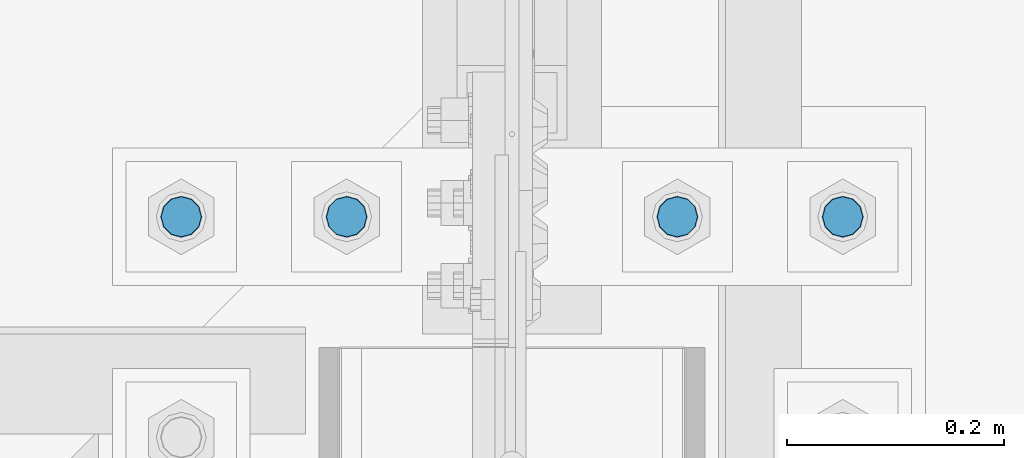
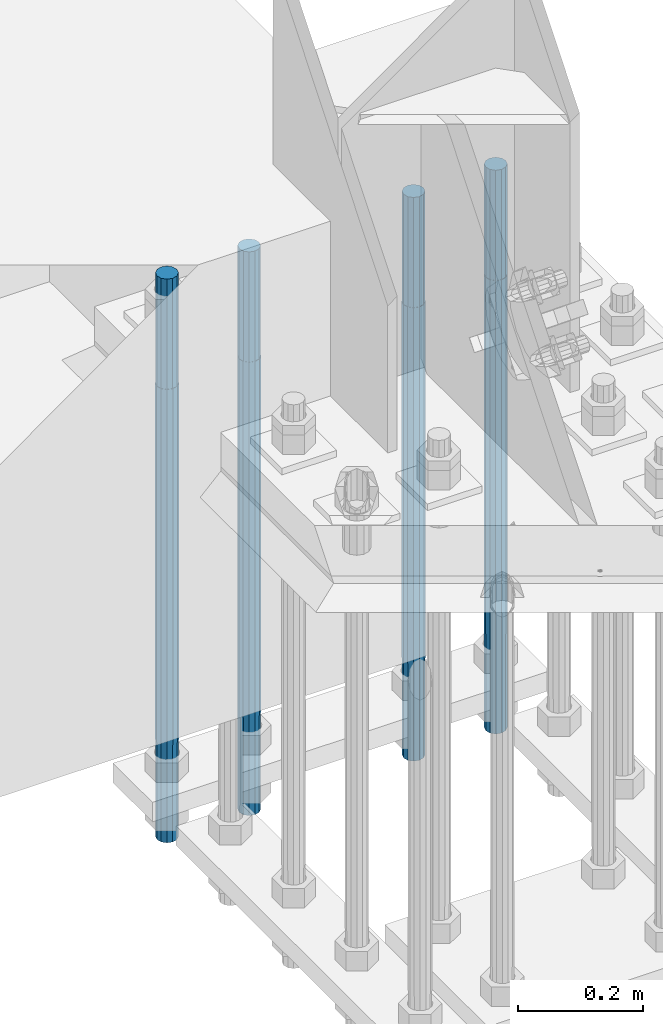
# One storey, part 1318 of 3843: 4 columns, 1 element without a shape of its own.
"""IFC2X3 building model written with IfcOpenShell, lengths in millimetres."""

from ifc_helpers import new_model, si_unit, frame, origin_with_axes, place, context, subcontext, project, spatial, faceted_brep, material, type_object, element, aggregate, save


model = new_model("IFC2X3")

# Units and contexts
model_context = context("Model", 3, precision=1e-05, world=origin_with_axes())
body_context = subcontext(model_context, "Body", "Model", "MODEL_VIEW")
ifc_project = project(units=[si_unit("LENGTHUNIT", "METRE", prefix="MILLI"), si_unit("AREAUNIT", "SQUARE_METRE"), si_unit("VOLUMEUNIT", "CUBIC_METRE"), si_unit("MASSUNIT", "GRAM", prefix="KILO"), si_unit("TIMEUNIT", "SECOND"), si_unit("PLANEANGLEUNIT", "RADIAN"), si_unit("SOLIDANGLEUNIT", "STERADIAN"), si_unit("THERMODYNAMICTEMPERATUREUNIT", "DEGREE_CELSIUS"), si_unit("LUMINOUSINTENSITYUNIT", "LUMEN")], contexts=[model_context])

# Site, building, storey
site_placement = place(None, origin_with_axes())
site = spatial("IfcSite", under=ifc_project, at=site_placement, CompositionType="ELEMENT")
building_placement = place(site_placement, origin_with_axes())
building = spatial("IfcBuilding", under=site, at=building_placement, Name="Undefined", CompositionType="ELEMENT")
storey_placement = place(building_placement, origin_with_axes())
storey = spatial("IfcBuildingStorey", under=building, at=storey_placement, Name="Undefined", CompositionType="ELEMENT", Elevation=0.0)

# Assembly, columns
assembly_placement = place(storey_placement, origin_with_axes())
assembly = element("IfcElementAssembly", 1, at=assembly_placement, inside=storey, Name="TEMPLATE", AssemblyPlace="NOTDEFINED", PredefinedType="RIGID_FRAME")
ifc_material = material(Name="Undefined/F1554-GR.55")
column_type = type_object("IfcColumnType", PredefinedType="NOTDEFINED")
column_1_placement = place(assembly_placement, frame((77317.6, 25920.7, 30022.8), z_axis=(-1.0, 0.0, 0.0), x_axis=(0.0, 0.0, -1.0)))
column_1 = element("IfcColumn", 2, at=column_1_placement, type_object=column_type, material=ifc_material, Name="ANCHOR_ROD", context=body_context, shape_type="Brep", body=[
    faceted_brep([(-215.899999999998, -16.0214699700118, 9.25), (-215.899999999998, -9.25, 16.0214699700155), (-215.899999999998, 0.0, 18.5), (-215.899999999998, 9.25, 16.0214699700155), (-215.899999999998, 16.0214699700118, 9.25), (-215.899999999998, 18.5, 0.0), (-215.899999999998, 16.0214699700118, -9.25), (-215.899999999998, 9.25, -16.0214699700155), (-215.899999999998, 0.0, -18.5), (-215.899999999998, -9.25, -16.0214699700155), (-215.899999999998, -16.0214699700118, -9.25), (-215.899999999998, -18.5, 0.0), (0.0, 18.5, 0.0), (0.0, 16.0214699700118, -9.25), (0.0, 9.25, -16.0214699700155), (0.0, 0.0, -18.5), (0.0, -9.25, -16.0214699700155), (0.0, -16.0214699700118, -9.25), (0.0, -18.5, 0.0), (0.0, -16.0214699700118, 9.25), (0.0, -9.25, 16.0214699700155), (0.0, 0.0, 18.5), (0.0, 9.25, 16.0214699700155), (0.0, 16.0214699700118, 9.25), (0.0, -16.4977839420972, 9.52500000000146), (0.0, -9.52500000000146, 16.4977839420972), (0.0, 0.0, 19.0499989999989), (0.0, 9.52500000000146, 16.4977839420972), (0.0, 16.4977839420972, 9.52500000000146), (0.0, 19.0500000000029, 0.0), (0.0, 16.4977839420972, -9.52500000000146), (0.0, 9.52500000000146, -16.4977839420972), (0.0, 0.0, -19.0499989999989), (0.0, -9.52500000000146, -16.4977839420972), (0.0, -16.4977839420972, -9.52500000000146), (0.0, -19.0500000000029, 0.0), (698.5, -19.0499999999993, 0.0), (698.5, -16.4977839420935, 9.52499999999418), (698.5, -9.52500000000146, 16.4977839420899), (698.5, 0.0, 19.0500000000029), (698.5, 9.52500000000146, 16.4977839420899), (698.5, 16.4977839420935, 9.52499999999418), (698.5, 19.0499999999993, 0.0), (698.5, 16.4977839420935, -9.52499999999418), (698.5, 9.52500000000146, -16.4977839420899), (698.5, 0.0, -19.0500000000029), (698.5, -9.52500000000146, -16.4977839420899), (698.5, -16.4977839420935, -9.52499999999418), (698.5, -9.25, 16.0214699700155), (698.5, 0.0, 18.5), (698.5, 9.25, 16.0214699700155), (698.5, 16.0214699700118, 9.25), (698.5, 18.5, 0.0), (698.5, 16.0214699700118, -9.25), (698.5, 9.25, -16.0214699700155), (698.5, 0.0, -18.5), (698.5, -9.25, -16.0214699700155), (698.5, -16.0214699700118, -9.25), (698.5, -18.5, 0.0), (698.5, -16.0214699700118, 9.25), (889.0, -9.25, -16.0214699700155), (889.0, 0.0, -18.5), (889.0, 9.25, -16.0214699700155), (889.0, 16.0214699700118, -9.25), (889.0, 18.5, 0.0), (889.0, 16.0214699700118, 9.25), (889.0, 9.25, 16.0214699700155), (889.0, 0.0, 18.5), (889.0, -9.25, 16.0214699700155), (889.0, -16.0214699700118, 9.25), (889.0, -18.5, 0.0), (889.0, -16.0214699700118, -9.25)], [[[0, 1, 2, 3, 4, 5, 6, 7, 8, 9, 10, 11]], [[6, 5, 12, 13]], [[7, 6, 13, 14]], [[8, 7, 14, 15]], [[9, 8, 15, 16]], [[10, 9, 16, 17]], [[11, 10, 17, 18]], [[0, 11, 18, 19]], [[1, 0, 19, 20]], [[2, 1, 20, 21]], [[3, 2, 21, 22]], [[4, 3, 22, 23]], [[5, 4, 23, 12]], [[24, 25, 26, 27, 28, 29, 30, 31, 32, 33, 34, 35], [22, 21, 20, 19, 18, 17, 16, 15, 14, 13, 12, 23]], [[24, 35, 36, 37]], [[25, 24, 37, 38]], [[26, 25, 38, 39]], [[27, 26, 39, 40]], [[28, 27, 40, 41]], [[29, 28, 41, 42]], [[30, 29, 42, 43]], [[31, 30, 43, 44]], [[32, 31, 44, 45]], [[33, 32, 45, 46]], [[34, 33, 46, 47]], [[35, 34, 47, 36]], [[46, 45, 44, 43, 42, 41, 40, 39, 38, 37, 36, 47], [48, 49, 50, 51, 52, 53, 54, 55, 56, 57, 58, 59]], [[60, 61, 62, 63, 64, 65, 66, 67, 68, 69, 70, 71]], [[68, 67, 49, 48]], [[69, 68, 48, 59]], [[70, 69, 59, 58]], [[71, 70, 58, 57]], [[60, 71, 57, 56]], [[61, 60, 56, 55]], [[62, 61, 55, 54]], [[63, 62, 54, 53]], [[64, 63, 53, 52]], [[65, 64, 52, 51]], [[66, 65, 51, 50]], [[67, 66, 50, 49]]]),
])
column_2_placement = place(assembly_placement, frame((77165.2, 25920.7, 30022.8), z_axis=(-1.0, 0.0, 0.0), x_axis=(0.0, 0.0, -1.0)))
column_2 = element("IfcColumn", 3, at=column_2_placement, type_object=column_type, material=ifc_material, Name="ANCHOR_ROD", context=body_context, shape_type="Brep", body=[
    faceted_brep([(-215.899999999998, -16.0214699700118, 9.25), (-215.899999999998, -9.25, 16.0214699700155), (-215.899999999998, 0.0, 18.5), (-215.899999999998, 9.25, 16.0214699700155), (-215.899999999998, 16.0214699700118, 9.25), (-215.899999999998, 18.5, 0.0), (-215.899999999998, 16.0214699700118, -9.25), (-215.899999999998, 9.25, -16.0214699700155), (-215.899999999998, 0.0, -18.5), (-215.899999999998, -9.25, -16.0214699700155), (-215.899999999998, -16.0214699700118, -9.25), (-215.899999999998, -18.5, 0.0), (0.0, 18.5, 0.0), (0.0, 16.0214699700118, -9.25), (0.0, 9.25, -16.0214699700155), (0.0, 0.0, -18.5), (0.0, -9.25, -16.0214699700155), (0.0, -16.0214699700118, -9.25), (0.0, -18.5, 0.0), (0.0, -16.0214699700118, 9.25), (0.0, -9.25, 16.0214699700155), (0.0, 0.0, 18.5), (0.0, 9.25, 16.0214699700155), (0.0, 16.0214699700118, 9.25), (0.0, -16.4977839420972, 9.52500000000146), (0.0, -9.52500000000146, 16.4977839420972), (0.0, 0.0, 19.0499989999989), (0.0, 9.52500000000146, 16.4977839420972), (0.0, 16.4977839420972, 9.52500000000146), (0.0, 19.0500000000029, 0.0), (0.0, 16.4977839420972, -9.52500000000146), (0.0, 9.52500000000146, -16.4977839420972), (0.0, 0.0, -19.0499989999989), (0.0, -9.52500000000146, -16.4977839420972), (0.0, -16.4977839420972, -9.52500000000146), (0.0, -19.0500000000029, 0.0), (698.5, -19.0499999999993, 0.0), (698.5, -16.4977839420935, 9.52499999999418), (698.5, -9.52500000000146, 16.4977839420899), (698.5, 0.0, 19.0500000000029), (698.5, 9.52500000000146, 16.4977839420899), (698.5, 16.4977839420935, 9.52499999999418), (698.5, 19.0499999999993, 0.0), (698.5, 16.4977839420935, -9.52499999999418), (698.5, 9.52500000000146, -16.4977839420899), (698.5, 0.0, -19.0500000000029), (698.5, -9.52500000000146, -16.4977839420899), (698.5, -16.4977839420935, -9.52499999999418), (698.5, -9.25, 16.0214699700155), (698.5, 0.0, 18.5), (698.5, 9.25, 16.0214699700155), (698.5, 16.0214699700118, 9.25), (698.5, 18.5, 0.0), (698.5, 16.0214699700118, -9.25), (698.5, 9.25, -16.0214699700155), (698.5, 0.0, -18.5), (698.5, -9.25, -16.0214699700155), (698.5, -16.0214699700118, -9.25), (698.5, -18.5, 0.0), (698.5, -16.0214699700118, 9.25), (889.0, -9.25, -16.0214699700155), (889.0, 0.0, -18.5), (889.0, 9.25, -16.0214699700155), (889.0, 16.0214699700118, -9.25), (889.0, 18.5, 0.0), (889.0, 16.0214699700118, 9.25), (889.0, 9.25, 16.0214699700155), (889.0, 0.0, 18.5), (889.0, -9.25, 16.0214699700155), (889.0, -16.0214699700118, 9.25), (889.0, -18.5, 0.0), (889.0, -16.0214699700118, -9.25)], [[[0, 1, 2, 3, 4, 5, 6, 7, 8, 9, 10, 11]], [[6, 5, 12, 13]], [[7, 6, 13, 14]], [[8, 7, 14, 15]], [[9, 8, 15, 16]], [[10, 9, 16, 17]], [[11, 10, 17, 18]], [[0, 11, 18, 19]], [[1, 0, 19, 20]], [[2, 1, 20, 21]], [[3, 2, 21, 22]], [[4, 3, 22, 23]], [[5, 4, 23, 12]], [[24, 25, 26, 27, 28, 29, 30, 31, 32, 33, 34, 35], [22, 21, 20, 19, 18, 17, 16, 15, 14, 13, 12, 23]], [[24, 35, 36, 37]], [[25, 24, 37, 38]], [[26, 25, 38, 39]], [[27, 26, 39, 40]], [[28, 27, 40, 41]], [[29, 28, 41, 42]], [[30, 29, 42, 43]], [[31, 30, 43, 44]], [[32, 31, 44, 45]], [[33, 32, 45, 46]], [[34, 33, 46, 47]], [[35, 34, 47, 36]], [[46, 45, 44, 43, 42, 41, 40, 39, 38, 37, 36, 47], [48, 49, 50, 51, 52, 53, 54, 55, 56, 57, 58, 59]], [[60, 61, 62, 63, 64, 65, 66, 67, 68, 69, 70, 71]], [[68, 67, 49, 48]], [[69, 68, 48, 59]], [[70, 69, 59, 58]], [[71, 70, 58, 57]], [[60, 71, 57, 56]], [[61, 60, 56, 55]], [[62, 61, 55, 54]], [[63, 62, 54, 53]], [[64, 63, 53, 52]], [[65, 64, 52, 51]], [[66, 65, 51, 50]], [[67, 66, 50, 49]]]),
])
column_3_placement = place(assembly_placement, frame((76860.4, 25920.7, 30022.8), z_axis=(-1.0, 0.0, 0.0), x_axis=(0.0, 0.0, -1.0)))
column_3 = element("IfcColumn", 4, at=column_3_placement, type_object=column_type, material=ifc_material, Name="ANCHOR_ROD", context=body_context, shape_type="Brep", body=[
    faceted_brep([(-215.899999999998, -16.0214699700118, 9.25), (-215.899999999998, -9.25, 16.0214699700155), (-215.899999999998, 0.0, 18.5), (-215.899999999998, 9.25, 16.0214699700155), (-215.899999999998, 16.0214699700118, 9.25), (-215.899999999998, 18.5, 0.0), (-215.899999999998, 16.0214699700118, -9.25), (-215.899999999998, 9.25, -16.0214699700155), (-215.899999999998, 0.0, -18.5), (-215.899999999998, -9.25, -16.0214699700155), (-215.899999999998, -16.0214699700118, -9.25), (-215.899999999998, -18.5, 0.0), (0.0, 18.5, 0.0), (0.0, 16.0214699700118, -9.25), (0.0, 9.25, -16.0214699700155), (0.0, 0.0, -18.5), (0.0, -9.25, -16.0214699700155), (0.0, -16.0214699700118, -9.25), (0.0, -18.5, 0.0), (0.0, -16.0214699700118, 9.25), (0.0, -9.25, 16.0214699700155), (0.0, 0.0, 18.5), (0.0, 9.25, 16.0214699700155), (0.0, 16.0214699700118, 9.25), (0.0, -16.4977839420972, 9.52500000000146), (0.0, -9.52500000000146, 16.4977839420972), (0.0, 0.0, 19.0499989999989), (0.0, 9.52500000000146, 16.4977839420972), (0.0, 16.4977839420972, 9.52500000000146), (0.0, 19.0500000000029, 0.0), (0.0, 16.4977839420972, -9.52500000000146), (0.0, 9.52500000000146, -16.4977839420972), (0.0, 0.0, -19.0499989999989), (0.0, -9.52500000000146, -16.4977839420972), (0.0, -16.4977839420972, -9.52500000000146), (0.0, -19.0500000000029, 0.0), (698.5, -19.0499999999993, 0.0), (698.5, -16.4977839420935, 9.52499999999418), (698.5, -9.52500000000146, 16.4977839420899), (698.5, 0.0, 19.0500000000029), (698.5, 9.52500000000146, 16.4977839420899), (698.5, 16.4977839420935, 9.52499999999418), (698.5, 19.0499999999993, 0.0), (698.5, 16.4977839420935, -9.52499999999418), (698.5, 9.52500000000146, -16.4977839420899), (698.5, 0.0, -19.0500000000029), (698.5, -9.52500000000146, -16.4977839420899), (698.5, -16.4977839420935, -9.52499999999418), (698.5, -9.25, 16.0214699700155), (698.5, 0.0, 18.5), (698.5, 9.25, 16.0214699700155), (698.5, 16.0214699700118, 9.25), (698.5, 18.5, 0.0), (698.5, 16.0214699700118, -9.25), (698.5, 9.25, -16.0214699700155), (698.5, 0.0, -18.5), (698.5, -9.25, -16.0214699700155), (698.5, -16.0214699700118, -9.25), (698.5, -18.5, 0.0), (698.5, -16.0214699700118, 9.25), (889.0, -9.25, -16.0214699700155), (889.0, 0.0, -18.5), (889.0, 9.25, -16.0214699700155), (889.0, 16.0214699700118, -9.25), (889.0, 18.5, 0.0), (889.0, 16.0214699700118, 9.25), (889.0, 9.25, 16.0214699700155), (889.0, 0.0, 18.5), (889.0, -9.25, 16.0214699700155), (889.0, -16.0214699700118, 9.25), (889.0, -18.5, 0.0), (889.0, -16.0214699700118, -9.25)], [[[0, 1, 2, 3, 4, 5, 6, 7, 8, 9, 10, 11]], [[6, 5, 12, 13]], [[7, 6, 13, 14]], [[8, 7, 14, 15]], [[9, 8, 15, 16]], [[10, 9, 16, 17]], [[11, 10, 17, 18]], [[0, 11, 18, 19]], [[1, 0, 19, 20]], [[2, 1, 20, 21]], [[3, 2, 21, 22]], [[4, 3, 22, 23]], [[5, 4, 23, 12]], [[24, 25, 26, 27, 28, 29, 30, 31, 32, 33, 34, 35], [22, 21, 20, 19, 18, 17, 16, 15, 14, 13, 12, 23]], [[24, 35, 36, 37]], [[25, 24, 37, 38]], [[26, 25, 38, 39]], [[27, 26, 39, 40]], [[28, 27, 40, 41]], [[29, 28, 41, 42]], [[30, 29, 42, 43]], [[31, 30, 43, 44]], [[32, 31, 44, 45]], [[33, 32, 45, 46]], [[34, 33, 46, 47]], [[35, 34, 47, 36]], [[46, 45, 44, 43, 42, 41, 40, 39, 38, 37, 36, 47], [48, 49, 50, 51, 52, 53, 54, 55, 56, 57, 58, 59]], [[60, 61, 62, 63, 64, 65, 66, 67, 68, 69, 70, 71]], [[68, 67, 49, 48]], [[69, 68, 48, 59]], [[70, 69, 59, 58]], [[71, 70, 58, 57]], [[60, 71, 57, 56]], [[61, 60, 56, 55]], [[62, 61, 55, 54]], [[63, 62, 54, 53]], [[64, 63, 53, 52]], [[65, 64, 52, 51]], [[66, 65, 51, 50]], [[67, 66, 50, 49]]]),
])
column_4_placement = place(assembly_placement, frame((76708.0, 25920.7, 30022.8), z_axis=(-1.0, 0.0, 0.0), x_axis=(0.0, 0.0, -1.0)))
column_4 = element("IfcColumn", 5, at=column_4_placement, type_object=column_type, material=ifc_material, Name="ANCHOR_ROD", context=body_context, shape_type="Brep", body=[
    faceted_brep([(-215.899999999998, -16.0214699700118, 9.25), (-215.899999999998, -9.25, 16.0214699700155), (-215.899999999998, 0.0, 18.5), (-215.899999999998, 9.25, 16.0214699700155), (-215.899999999998, 16.0214699700118, 9.25), (-215.899999999998, 18.5, 0.0), (-215.899999999998, 16.0214699700118, -9.25), (-215.899999999998, 9.25, -16.0214699700155), (-215.899999999998, 0.0, -18.5), (-215.899999999998, -9.25, -16.0214699700155), (-215.899999999998, -16.0214699700118, -9.25), (-215.899999999998, -18.5, 0.0), (0.0, 18.5, 0.0), (0.0, 16.0214699700118, -9.25), (0.0, 9.25, -16.0214699700155), (0.0, 0.0, -18.5), (0.0, -9.25, -16.0214699700155), (0.0, -16.0214699700118, -9.25), (0.0, -18.5, 0.0), (0.0, -16.0214699700118, 9.25), (0.0, -9.25, 16.0214699700155), (0.0, 0.0, 18.5), (0.0, 9.25, 16.0214699700155), (0.0, 16.0214699700118, 9.25), (0.0, -16.4977839420972, 9.52500000000146), (0.0, -9.52500000000146, 16.4977839420972), (0.0, 0.0, 19.0499989999989), (0.0, 9.52500000000146, 16.4977839420972), (0.0, 16.4977839420972, 9.52500000000146), (0.0, 19.0500000000029, 0.0), (0.0, 16.4977839420972, -9.52500000000146), (0.0, 9.52500000000146, -16.4977839420972), (0.0, 0.0, -19.0499989999989), (0.0, -9.52500000000146, -16.4977839420972), (0.0, -16.4977839420972, -9.52500000000146), (0.0, -19.0500000000029, 0.0), (698.5, -19.0499999999993, 0.0), (698.5, -16.4977839420935, 9.52499999999418), (698.5, -9.52500000000146, 16.4977839420899), (698.5, 0.0, 19.0500000000029), (698.5, 9.52500000000146, 16.4977839420899), (698.5, 16.4977839420935, 9.52499999999418), (698.5, 19.0499999999993, 0.0), (698.5, 16.4977839420935, -9.52499999999418), (698.5, 9.52500000000146, -16.4977839420899), (698.5, 0.0, -19.0500000000029), (698.5, -9.52500000000146, -16.4977839420899), (698.5, -16.4977839420935, -9.52499999999418), (698.5, -9.25, 16.0214699700155), (698.5, 0.0, 18.5), (698.5, 9.25, 16.0214699700155), (698.5, 16.0214699700118, 9.25), (698.5, 18.5, 0.0), (698.5, 16.0214699700118, -9.25), (698.5, 9.25, -16.0214699700155), (698.5, 0.0, -18.5), (698.5, -9.25, -16.0214699700155), (698.5, -16.0214699700118, -9.25), (698.5, -18.5, 0.0), (698.5, -16.0214699700118, 9.25), (889.0, -9.25, -16.0214699700155), (889.0, 0.0, -18.5), (889.0, 9.25, -16.0214699700155), (889.0, 16.0214699700118, -9.25), (889.0, 18.5, 0.0), (889.0, 16.0214699700118, 9.25), (889.0, 9.25, 16.0214699700155), (889.0, 0.0, 18.5), (889.0, -9.25, 16.0214699700155), (889.0, -16.0214699700118, 9.25), (889.0, -18.5, 0.0), (889.0, -16.0214699700118, -9.25)], [[[0, 1, 2, 3, 4, 5, 6, 7, 8, 9, 10, 11]], [[6, 5, 12, 13]], [[7, 6, 13, 14]], [[8, 7, 14, 15]], [[9, 8, 15, 16]], [[10, 9, 16, 17]], [[11, 10, 17, 18]], [[0, 11, 18, 19]], [[1, 0, 19, 20]], [[2, 1, 20, 21]], [[3, 2, 21, 22]], [[4, 3, 22, 23]], [[5, 4, 23, 12]], [[24, 25, 26, 27, 28, 29, 30, 31, 32, 33, 34, 35], [22, 21, 20, 19, 18, 17, 16, 15, 14, 13, 12, 23]], [[24, 35, 36, 37]], [[25, 24, 37, 38]], [[26, 25, 38, 39]], [[27, 26, 39, 40]], [[28, 27, 40, 41]], [[29, 28, 41, 42]], [[30, 29, 42, 43]], [[31, 30, 43, 44]], [[32, 31, 44, 45]], [[33, 32, 45, 46]], [[34, 33, 46, 47]], [[35, 34, 47, 36]], [[46, 45, 44, 43, 42, 41, 40, 39, 38, 37, 36, 47], [48, 49, 50, 51, 52, 53, 54, 55, 56, 57, 58, 59]], [[60, 61, 62, 63, 64, 65, 66, 67, 68, 69, 70, 71]], [[68, 67, 49, 48]], [[69, 68, 48, 59]], [[70, 69, 59, 58]], [[71, 70, 58, 57]], [[60, 71, 57, 56]], [[61, 60, 56, 55]], [[62, 61, 55, 54]], [[63, 62, 54, 53]], [[64, 63, 53, 52]], [[65, 64, 52, 51]], [[66, 65, 51, 50]], [[67, 66, 50, 49]]]),
])
aggregate(assembly, [column_1, column_2, column_3, column_4])

save(model, "model.ifc")
